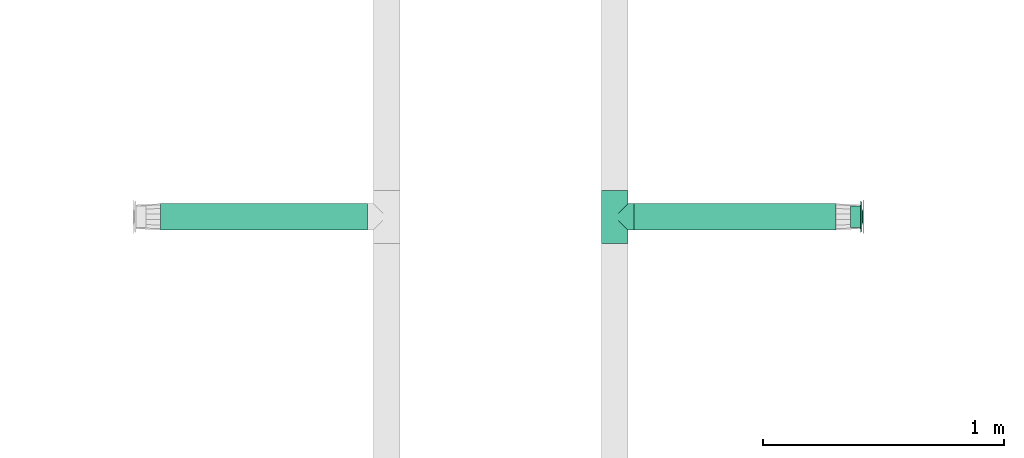
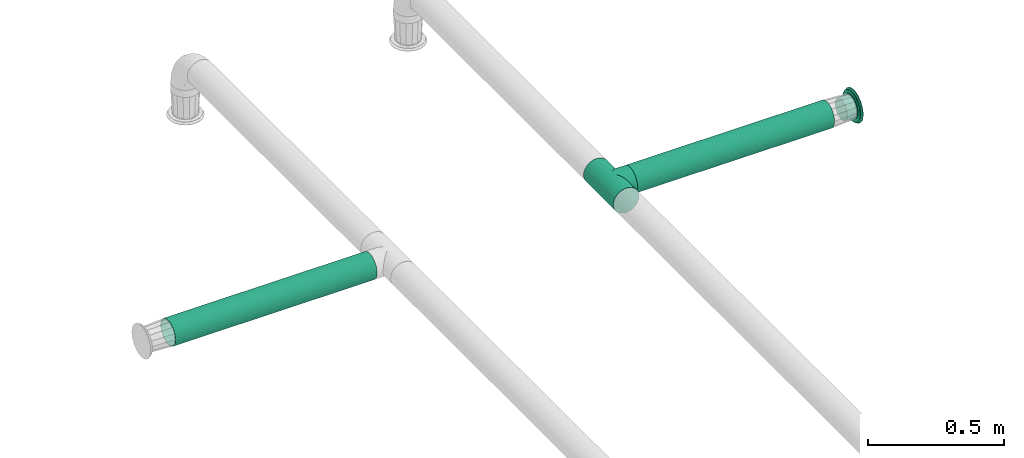
# One storey, part 40 of 123: 2 flow segments, 1 flow fitting, 1 flow terminal.
"""IFC2X3 building model written with IfcOpenShell, lengths in millimetres."""

from ifc_helpers import new_model, entity, si_unit, converted_unit, derived_unit, direction, frame, origin_with_axes, origin_2d_with_axis, place, context, subcontext, project, spatial, hollow_circle, extrude, open_shell, surface_model, source, transform, mapped, material, layer, layer_set, layer_usage, type_object, element, save


model = new_model("IFC2X3")

# Units and contexts
model_context = context("Model", 3, precision=1e-05, world=origin_with_axes(), true_north=direction((0.0, 1.0)))
body_context = subcontext(model_context, "Body", "Model", "MODEL_VIEW")
ifc_project = project(units=[si_unit("AREAUNIT", "SQUARE_METRE"), si_unit("VOLUMEUNIT", "CUBIC_METRE", prefix="DECI"), si_unit("TIMEUNIT", "SECOND"), si_unit("THERMODYNAMICTEMPERATUREUNIT", "DEGREE_CELSIUS"), si_unit("PRESSUREUNIT", "PASCAL"), si_unit("MASSUNIT", "GRAM", prefix="KILO"), si_unit("LENGTHUNIT", "METRE", prefix="MILLI"), si_unit("POWERUNIT", "WATT"), si_unit("ELECTRICCURRENTUNIT", "AMPERE"), si_unit("ELECTRICVOLTAGEUNIT", "VOLT"), derived_unit("VOLUMETRICFLOWRATEUNIT", [(si_unit("VOLUMEUNIT", "CUBIC_METRE", prefix="DECI"), 1), (si_unit("TIMEUNIT", "SECOND"), -1)]), derived_unit("LINEARVELOCITYUNIT", [(si_unit("LENGTHUNIT", "METRE"), 1), (si_unit("TIMEUNIT", "SECOND"), -1)]), derived_unit("MASSDENSITYUNIT", [(si_unit("MASSUNIT", "GRAM", prefix="KILO"), 1), (si_unit("VOLUMEUNIT", "CUBIC_METRE"), -1)]), converted_unit("PLANEANGLEUNIT", "DEGREE", entity("IfcRatioMeasure", 0.01745), si_unit("PLANEANGLEUNIT", "RADIAN"), dimensions=[0, 0, 0, 0, 0, 0, 0])], contexts=[model_context])

# Site, building, storey
site_placement = place(None, origin_with_axes())
site = spatial("IfcSite", under=ifc_project, at=site_placement, CompositionType="ELEMENT")
building_placement = place(site_placement, origin_with_axes())
building = spatial("IfcBuilding", under=site, at=building_placement, Name="mc-building", CompositionType="ELEMENT")
storey_placement = place(building_placement, origin_with_axes())
storey = spatial("IfcBuildingStorey", under=building, at=storey_placement, Name="1. Korrus", CompositionType="ELEMENT", Elevation=0.0)

# Flow terminal
air_terminal_type = type_object("IfcAirTerminalType", Name="100", PredefinedType="NOTDEFINED")
shared_shape_1 = source(origin_with_axes(), body_context, "Body", "SurfaceModel", [
    surface_model("IfcShellBasedSurfaceModel", [(11.2, 18.11733, -67.61481), (11.2, -18.11733, -67.61481), (11.2, 0.0, -70.0), (11.2, 67.61481, -18.11733), (11.2, 35.0, -60.62178), (11.2, 49.49747, -49.49747), (11.2, 60.62178, -35.0), (11.2, -67.61481, 18.11733), (11.2, -49.49747, -49.49747), (11.2, -67.61481, -18.11733), (11.2, -35.0, -60.62178), (11.2, -60.62178, -35.0), (11.2, -70.0, 0.0), (11.2, 18.11733, 67.61481), (11.2, 70.0, 0.0), (11.2, 67.61481, 18.11733), (11.2, 49.49747, 49.49747), (11.2, 60.62178, 35.0), (11.2, 35.0, 60.62178), (11.2, -49.49747, 49.49747), (11.2, -60.62178, 35.0), (11.2, -35.0, 60.62178), (11.2, -18.11733, 67.61481), (11.2, 0.0, 70.0), (9.2, 18.11733, 67.61481), (9.2, -67.61481, 18.11733), (9.2, 0.0, 70.0), (9.2, 49.49747, 49.49747), (9.2, 35.0, 60.62178), (9.2, 60.62178, 35.0), (9.2, 67.61481, 18.11733), (9.2, -35.0, 60.62178), (9.2, -49.49747, 49.49747), (9.2, -18.11733, 67.61481), (9.2, -60.62178, 35.0), (9.2, -67.61481, -18.11733), (9.2, -70.0, 0.0), (9.2, 67.61481, -18.11733), (9.2, 18.11733, -67.61481), (9.2, 49.49747, -49.49747), (9.2, 60.62178, -35.0), (9.2, 35.0, -60.62178), (9.2, -18.11733, -67.61481), (9.2, -49.49747, -49.49747), (9.2, -60.62178, -35.0), (9.2, -35.0, -60.62178), (9.2, 0.0, -70.0), (9.2, 70.0, 0.0), (9.2, 32.75, 0.0), (9.2, -16.375, 28.36233), (9.2, -28.36233, 16.375), (9.2, 16.375, 28.36233), (9.2, 0.0, 32.75), (9.2, 28.36233, 16.375), (9.2, -32.75, 0.0), (9.2, -16.375, -28.36233), (9.2, 16.375, -28.36233), (9.2, 0.0, -32.75), (9.2, 28.36233, -16.375), (9.2, -28.36233, -16.375), (6.2, -21.19625, -15.39997), (6.2, -21.19625, 15.39997), (6.2, 8.09625, 24.91768), (6.2, -8.09625, 24.91768), (6.2, -26.2, 0.0), (6.2, 21.19625, 15.39997), (6.2, -8.09625, -24.91768), (6.2, 21.19625, -15.39997), (6.2, 8.09625, -24.91768), (6.2, 26.2, 0.0), (9.2, 31.06579, -6.28555), (6.2, 23.69812, -7.69999), (6.2, -14.64625, -20.15883), (9.2, -22.36867, -22.36867), (6.2, -23.69812, -7.69999), (9.2, -31.06579, -6.28555), (6.2, 14.64625, -20.15883), (9.2, 8.1875, -30.55617), (6.2, 0.0, -24.91768), (9.2, 22.36867, -22.36867), (9.2, -8.1875, -30.55617), (9.2, -31.06579, 6.28555), (6.2, -23.69812, 7.69999), (6.2, 14.64625, 20.15883), (9.2, 22.36867, 22.36867), (6.2, 23.69812, 7.69999), (9.2, 31.06579, 6.28555), (6.2, -14.64625, 20.15883), (9.2, -8.1875, 30.55617), (6.2, 0.0, 24.91768), (9.2, -22.36867, 22.36867), (9.2, 8.1875, 30.55617), (6.2, -13.11761, 57.472), (6.2, -36.75472, 46.08897), (6.2, -53.11211, 25.57744), (6.2, 36.75472, 46.08897), (6.2, -58.95, 0.0), (6.2, 13.11761, 57.472), (6.2, 53.11211, 25.57744), (6.2, -53.11211, -25.57744), (6.2, -36.75472, -46.08897), (6.2, -13.11761, -57.472), (6.2, 58.95, 0.0), (6.2, 53.11211, -25.57744), (6.2, 13.11761, -57.472), (6.2, 36.75472, -46.08897), (0.0, -60.51411, 25.06576), (0.0, 0.0, 65.5), (0.0, 25.06576, 60.51411), (0.0, 46.3155, 46.3155), (0.0, 60.51411, 25.06576), (0.0, -46.3155, 46.3155), (0.0, -25.06576, 60.51411), (0.0, 0.0, -65.5), (0.0, -65.5, 0.0), (0.0, 65.5, 0.0), (0.0, 60.51411, -25.06576), (0.0, 46.3155, -46.3155), (0.0, 25.06576, -60.51411), (0.0, -46.3155, -46.3155), (0.0, -60.51411, -25.06576), (0.0, -25.06576, -60.51411), (6.2, 56.03105, -12.78872), (0.0, 53.4148, -35.69063), (0.0, 35.69063, -53.4148), (6.2, 24.93616, -51.78048), (0.0, -12.53288, -63.00706), (6.2, 0.0, -57.472), (0.0, -35.69063, -53.4148), (0.0, 63.00706, -12.53288), (6.2, 44.93342, -35.83321), (6.2, -24.93616, -51.78048), (6.2, -44.93342, -35.83321), (0.0, -53.4148, -35.69063), (0.0, 12.53288, -63.00706), (6.2, -56.03105, -12.78872), (0.0, -63.00706, -12.53288), (6.2, -56.03105, 12.78872), (0.0, -53.4148, 35.69063), (0.0, -35.69063, 53.4148), (6.2, -24.93616, 51.78048), (0.0, 12.53288, 63.00706), (6.2, 0.0, 57.472), (0.0, 35.69063, 53.4148), (0.0, -63.00706, 12.53288), (6.2, -44.93342, 35.83321), (6.2, 24.93616, 51.78048), (6.2, 44.93342, 35.83321), (0.0, 53.4148, 35.69063), (0.0, -12.53288, 63.00706), (6.2, 56.03105, 12.78872), (0.0, 63.00706, 12.53288), (-3.1, 12.94095, 48.29629), (-3.1, -35.35534, 35.35534), (-3.1, 0.0, 50.0), (-3.1, 35.35534, 35.35534), (-3.1, 25.0, 43.30127), (-3.1, -43.30127, 25.0), (-3.1, 43.30127, 25.0), (-3.1, -48.29629, -12.94095), (-3.1, -12.94095, 48.29629), (-3.1, -25.0, 43.30127), (-3.1, -50.0, 0.0), (-3.1, -48.29629, 12.94095), (-3.1, 48.29629, 12.94095), (-3.1, 12.94095, -48.29629), (-3.1, 50.0, 0.0), (-3.1, 48.29629, -12.94095), (-3.1, 35.35534, -35.35534), (-3.1, 43.30127, -25.0), (-3.1, 25.0, -43.30127), (-3.1, 0.0, -50.0), (-3.1, -35.35534, -35.35534), (-3.1, -43.30127, -25.0), (-3.1, -25.0, -43.30127), (-3.1, -12.94095, -48.29629), (0.0, 25.0, -43.30127), (0.0, 0.0, -50.0), (0.0, 12.94095, -48.29629), (0.0, 48.29629, -12.94095), (0.0, 35.35534, -35.35534), (0.0, -25.0, -43.30127), (0.0, 43.30127, -25.0), (0.0, -50.0, 0.0), (0.0, -12.94095, -48.29629), (0.0, -35.35534, -35.35534), (0.0, -48.29629, -12.94095), (0.0, -43.30127, -25.0), (0.0, 50.0, 0.0), (0.0, 43.30127, 25.0), (0.0, 12.94095, 48.29629), (0.0, 35.35534, 35.35534), (0.0, 25.0, 43.30127), (0.0, 0.0, 50.0), (0.0, -35.35534, 35.35534), (0.0, -43.30127, 25.0), (0.0, -48.29629, 12.94095), (0.0, -12.94095, 48.29629), (0.0, -25.0, 43.30127), (0.0, 48.29629, 12.94095), (-43.1, 0.0, 45.0), (-43.1, 11.64686, 43.46666), (-43.1, 22.5, 38.97115), (-43.1, -11.64686, 43.46666), (-43.1, 38.97115, 22.5), (-43.1, 43.46666, 11.64686), (-43.1, 31.81981, 31.81981), (-43.1, -22.5, 38.97115), (-43.1, -43.46666, 11.64686), (-43.1, -31.81981, 31.81981), (-43.1, -38.97115, 22.5), (-43.1, -45.0, 0.0), (-43.1, -43.46666, -11.64686), (-43.1, 45.0, 0.0), (-43.1, 43.46666, -11.64686), (-43.1, 38.97115, -22.5), (-43.1, 31.81981, -31.81981), (-43.1, 22.5, -38.97115), (-43.1, 11.64686, -43.46666), (-43.1, -31.81981, -31.81981), (-43.1, -38.97115, -22.5), (-43.1, -22.5, -38.97115), (-43.1, 0.0, -45.0), (-43.1, -11.64686, -43.46666), (-3.1, 22.5, -38.97115), (-3.1, 0.0, -45.0), (-3.1, 11.64686, -43.46666), (-3.1, 31.81981, -31.81981), (-3.1, -22.5, -38.97115), (-3.1, 38.97115, -22.5), (-3.1, 43.46666, -11.64686), (-3.1, 45.0, 0.0), (-3.1, -45.0, 0.0), (-3.1, -11.64686, -43.46666), (-3.1, -31.81981, -31.81981), (-3.1, -43.46666, -11.64686), (-3.1, -38.97115, -22.5), (-3.1, 0.0, 45.0), (-3.1, 43.46666, 11.64686), (-3.1, 38.97115, 22.5), (-3.1, 22.5, 38.97115), (-3.1, 31.81981, 31.81981), (-3.1, 11.64686, 43.46666), (-3.1, -11.64686, 43.46666), (-3.1, -43.46666, 11.64686), (-3.1, -31.81981, 31.81981), (-3.1, -38.97115, 22.5), (-3.1, -22.5, 38.97115)], [open_shell([[[0, 1, 2]], [[3, 0, 4]], [[5, 6, 3]], [[5, 3, 4]], [[7, 1, 0]], [[8, 7, 9]], [[10, 7, 8]], [[8, 9, 11]], [[12, 9, 7]], [[1, 7, 10]], [[7, 0, 3]], [[13, 14, 15]], [[16, 15, 17]], [[16, 18, 13]], [[16, 13, 15]], [[14, 13, 7]], [[7, 19, 20]], [[19, 7, 21]], [[7, 22, 21]], [[22, 7, 23]], [[7, 13, 23]], [[14, 7, 3]], [[24, 25, 26]], [[27, 24, 28]], [[27, 29, 30]], [[27, 30, 24]], [[25, 24, 30]], [[31, 25, 32]], [[25, 31, 33]], [[32, 25, 34]], [[33, 26, 25]], [[25, 35, 36]], [[25, 30, 37]], [[25, 37, 38]], [[39, 37, 40]], [[39, 41, 38]], [[39, 38, 37]], [[38, 42, 25]], [[35, 43, 44]], [[35, 25, 43]], [[45, 43, 25]], [[42, 45, 25]], [[38, 46, 42]], [[37, 30, 47]], [[35, 9, 36]], [[44, 11, 35]], [[10, 43, 45]], [[44, 43, 8]], [[1, 45, 42]], [[35, 11, 9]], [[9, 12, 36]], [[1, 10, 45]], [[8, 43, 10]], [[8, 11, 44]], [[2, 1, 42]], [[42, 46, 2]], [[38, 0, 46]], [[41, 4, 38]], [[6, 39, 40]], [[41, 39, 5]], [[3, 40, 37]], [[41, 5, 4]], [[4, 0, 38]], [[14, 3, 37]], [[6, 40, 3]], [[6, 5, 39]], [[47, 14, 37]], [[46, 0, 2]], [[30, 15, 47]], [[29, 17, 30]], [[18, 27, 28]], [[29, 27, 16]], [[13, 28, 24]], [[30, 17, 15]], [[15, 14, 47]], [[13, 18, 28]], [[16, 27, 18]], [[16, 17, 29]], [[23, 13, 24]], [[24, 26, 23]], [[33, 22, 26]], [[31, 21, 33]], [[20, 32, 34]], [[31, 32, 19]], [[7, 34, 25]], [[31, 19, 21]], [[21, 22, 33]], [[12, 7, 25]], [[20, 34, 7]], [[20, 19, 32]], [[36, 12, 25]], [[26, 22, 23]], [[48, 49, 50]], [[48, 51, 49]], [[49, 51, 52]], [[53, 51, 48]], [[48, 50, 54]], [[54, 55, 48]], [[56, 55, 57]], [[55, 58, 48]], [[58, 55, 56]], [[55, 54, 59]], [[60, 61, 62]], [[62, 61, 63]], [[64, 61, 60]], [[62, 65, 66]], [[67, 68, 65]], [[66, 60, 62]], [[65, 68, 66]], [[69, 67, 65]], [[69, 48, 70]], [[58, 71, 70]], [[72, 73, 60]], [[59, 74, 60]], [[75, 64, 74]], [[56, 68, 76]], [[72, 66, 55]], [[73, 72, 55]], [[68, 77, 78]], [[64, 75, 54]], [[59, 75, 74]], [[70, 71, 69]], [[67, 79, 76]], [[80, 55, 66]], [[68, 56, 77]], [[56, 76, 79]], [[79, 67, 58]], [[71, 58, 67]], [[80, 78, 57]], [[77, 57, 78]], [[66, 78, 80]], [[59, 60, 73]], [[64, 54, 81]], [[50, 82, 81]], [[83, 84, 65]], [[53, 85, 65]], [[86, 69, 85]], [[49, 63, 87]], [[83, 62, 51]], [[84, 83, 51]], [[63, 88, 89]], [[69, 86, 48]], [[53, 86, 85]], [[81, 82, 64]], [[61, 90, 87]], [[91, 51, 62]], [[63, 49, 88]], [[49, 87, 90]], [[90, 61, 50]], [[82, 50, 61]], [[91, 89, 52]], [[88, 52, 89]], [[62, 89, 91]], [[53, 65, 84]], [[92, 93, 94]], [[95, 94, 96]], [[97, 92, 95]], [[95, 92, 94]], [[96, 98, 95]], [[96, 99, 98]], [[99, 100, 101]], [[101, 102, 98]], [[102, 101, 103]], [[104, 105, 103]], [[101, 104, 103]], [[101, 98, 99]], [[106, 107, 108]], [[109, 110, 108]], [[106, 108, 110]], [[111, 112, 106]], [[106, 112, 107]], [[106, 113, 114]], [[106, 110, 113]], [[115, 116, 117]], [[117, 113, 110]], [[113, 117, 118]], [[114, 119, 120]], [[121, 119, 114]], [[121, 114, 113]], [[115, 117, 110]], [[103, 116, 122]], [[123, 116, 103]], [[124, 125, 118]], [[101, 126, 127]], [[100, 119, 128]], [[102, 122, 129]], [[103, 130, 123]], [[102, 129, 115]], [[113, 127, 126]], [[125, 124, 105]], [[130, 105, 117]], [[118, 125, 104]], [[124, 117, 105]], [[131, 100, 128]], [[119, 100, 132]], [[133, 99, 120]], [[134, 118, 104]], [[122, 116, 129]], [[127, 134, 104]], [[131, 121, 101]], [[99, 133, 132]], [[128, 121, 131]], [[130, 117, 123]], [[101, 121, 126]], [[99, 135, 120]], [[96, 136, 135]], [[136, 120, 135]], [[134, 127, 113]], [[133, 119, 132]], [[136, 96, 114]], [[94, 106, 137]], [[138, 106, 94]], [[139, 140, 112]], [[97, 141, 142]], [[95, 109, 143]], [[96, 137, 144]], [[94, 145, 138]], [[96, 144, 114]], [[107, 142, 141]], [[140, 139, 93]], [[145, 93, 111]], [[112, 140, 92]], [[139, 111, 93]], [[146, 95, 143]], [[109, 95, 147]], [[148, 98, 110]], [[149, 112, 92]], [[137, 106, 144]], [[142, 149, 92]], [[146, 108, 97]], [[98, 148, 147]], [[143, 108, 146]], [[145, 111, 138]], [[97, 108, 141]], [[98, 150, 110]], [[102, 151, 150]], [[151, 110, 150]], [[149, 142, 107]], [[148, 109, 147]], [[151, 102, 115]], [[152, 153, 154]], [[155, 152, 156]], [[157, 152, 158]], [[158, 152, 155]], [[158, 159, 157]], [[160, 153, 161]], [[160, 154, 153]], [[157, 162, 163]], [[153, 152, 157]], [[157, 159, 162]], [[158, 164, 159]], [[165, 166, 167]], [[168, 167, 169]], [[170, 165, 167]], [[170, 167, 168]], [[166, 165, 171]], [[159, 172, 173]], [[172, 159, 174]], [[174, 171, 175]], [[159, 164, 174]], [[166, 171, 174]], [[174, 164, 166]], [[176, 177, 178]], [[179, 176, 180]], [[176, 179, 181]], [[179, 180, 182]], [[179, 183, 181]], [[177, 181, 184]], [[177, 176, 181]], [[185, 186, 187]], [[186, 185, 181]], [[181, 183, 186]], [[183, 179, 188]], [[183, 188, 189]], [[190, 189, 191]], [[189, 190, 183]], [[190, 191, 192]], [[193, 194, 190]], [[183, 195, 196]], [[183, 190, 195]], [[194, 197, 198]], [[194, 195, 190]], [[197, 194, 193]], [[189, 188, 199]], [[164, 199, 166]], [[158, 189, 164]], [[192, 155, 156]], [[158, 155, 191]], [[190, 156, 152]], [[164, 189, 199]], [[199, 188, 166]], [[190, 192, 156]], [[191, 155, 192]], [[191, 189, 158]], [[193, 190, 152]], [[152, 154, 193]], [[160, 197, 154]], [[161, 198, 160]], [[195, 153, 157]], [[161, 153, 194]], [[196, 157, 163]], [[161, 194, 198]], [[198, 197, 160]], [[183, 196, 163]], [[195, 157, 196]], [[195, 194, 153]], [[162, 183, 163]], [[154, 197, 193]], [[159, 186, 162]], [[173, 187, 159]], [[181, 172, 174]], [[173, 172, 185]], [[184, 174, 175]], [[159, 187, 186]], [[186, 183, 162]], [[184, 181, 174]], [[185, 172, 181]], [[185, 187, 173]], [[177, 184, 175]], [[175, 171, 177]], [[165, 178, 171]], [[170, 176, 165]], [[182, 168, 169]], [[170, 168, 180]], [[179, 169, 167]], [[170, 180, 176]], [[176, 178, 165]], [[188, 179, 167]], [[182, 169, 179]], [[182, 180, 168]], [[166, 188, 167]], [[171, 178, 177]], [[200, 201, 202]], [[203, 200, 202]], [[204, 205, 202]], [[204, 202, 206]], [[203, 202, 205]], [[207, 208, 209]], [[207, 203, 205]], [[209, 208, 210]], [[211, 208, 212]], [[208, 207, 212]], [[207, 205, 212]], [[213, 214, 215]], [[205, 215, 212]], [[212, 216, 217]], [[216, 212, 215]], [[218, 219, 217]], [[212, 219, 220]], [[212, 217, 219]], [[221, 222, 223]], [[222, 221, 219]], [[218, 222, 219]], [[215, 205, 213]], [[224, 225, 226]], [[227, 228, 224]], [[229, 230, 231]], [[228, 227, 229]], [[229, 232, 228]], [[225, 228, 233]], [[225, 224, 228]], [[234, 235, 236]], [[235, 234, 228]], [[228, 232, 235]], [[232, 229, 231]], [[237, 238, 239]], [[240, 239, 241]], [[240, 242, 237]], [[240, 237, 239]], [[238, 237, 243]], [[244, 245, 246]], [[247, 244, 232]], [[244, 247, 245]], [[232, 238, 247]], [[238, 243, 247]], [[238, 232, 231]], [[205, 238, 213]], [[204, 239, 205]], [[240, 206, 202]], [[204, 206, 241]], [[242, 202, 201]], [[205, 239, 238]], [[238, 231, 213]], [[240, 202, 242]], [[241, 206, 240]], [[241, 239, 204]], [[201, 237, 242]], [[201, 200, 237]], [[243, 203, 207]], [[209, 247, 207]], [[246, 210, 208]], [[209, 210, 245]], [[244, 208, 211]], [[203, 243, 200]], [[207, 247, 243]], [[200, 243, 237]], [[209, 245, 247]], [[210, 246, 245]], [[244, 246, 208]], [[211, 232, 244]], [[212, 235, 211]], [[220, 236, 212]], [[228, 219, 221]], [[220, 219, 234]], [[233, 221, 223]], [[212, 236, 235]], [[235, 232, 211]], [[233, 228, 221]], [[234, 219, 228]], [[234, 236, 220]], [[225, 233, 223]], [[223, 222, 225]], [[226, 218, 217]], [[216, 224, 217]], [[229, 215, 214]], [[216, 215, 227]], [[230, 214, 213]], [[218, 226, 222]], [[217, 224, 226]], [[222, 226, 225]], [[216, 227, 224]], [[215, 229, 227]], [[230, 229, 214]], [[213, 231, 230]]])]),
])
flow_terminal_placement = place(storey_placement, frame((17487.97051, 3217.8145, 2445.0), z_axis=(0.0, 0.0, 1.0), x_axis=(1.0, 0.0, 0.0)))
element("IfcFlowTerminal", 1, at=flow_terminal_placement, inside=storey, type_object=air_terminal_type, Name="100", context=body_context, shape_type="MappedRepresentation", body=[
    mapped(shared_shape_1, transform((0.0, 0.0, 0.0), scale=1.0)),
])

# Flow fitting
duct_fitting_type = type_object("IfcDuctFittingType", PredefinedType="JUNCTION")
shared_shape_2 = source(origin_with_axes(), body_context, "Body", "SurfaceModel", [
    surface_model("IfcShellBasedSurfaceModel", [(0.0, -80.0, -55.0), (14.23505, -80.0, -53.12592), (-14.23505, -80.0, -53.12592), (-53.12592, -80.0, 14.23505), (-27.5, -80.0, -47.63139), (-47.63139, -80.0, -27.5), (-38.89087, -80.0, -38.89087), (55.0, -80.0, 0.0), (53.12592, -80.0, 14.23505), (38.89087, -80.0, -38.89087), (27.5, -80.0, -47.63139), (53.12592, -80.0, -14.23505), (47.63139, -80.0, -27.5), (-53.12592, -80.0, -14.23505), (-47.63139, -80.0, 27.5), (-38.89087, -80.0, 38.89087), (14.23505, -80.0, 53.12592), (-27.5, -80.0, 47.63139), (-14.23505, -80.0, 53.12592), (47.63139, -80.0, 27.5), (38.89087, -80.0, 38.89087), (27.5, -80.0, 47.63139), (0.0, -80.0, 55.0), (-55.0, -80.0, 0.0), (0.0, 0.0, 55.0), (-7.4066, -7.4066, 54.49901), (-14.74521, -14.74521, 52.98659), (-21.93978, -21.93978, 50.43457), (-28.89905, -28.89905, 46.79578), (-35.50357, -35.50357, 42.00591), (-41.58668, -41.58668, 35.99373), (-46.92319, -46.92319, 28.69171), (-51.19777, -51.19777, 20.0945), (-50.37866, -80.0, 20.86752), (-54.01174, -54.01174, 10.37938), (-55.0, -55.0, 0.0), (-54.06296, -80.0, 7.11752), (-54.01174, -54.01174, -10.37938), (-51.19777, -51.19777, -20.0945), (-54.06296, -80.0, -7.11752), (-46.92319, -46.92319, -28.69171), (-41.58668, -41.58668, -35.99373), (-50.37866, -80.0, -20.86752), (-35.50357, -35.50357, -42.00591), (-21.93978, -21.93978, -50.43457), (-14.74521, -14.74521, -52.98659), (-7.4066, -7.4066, -54.49901), (0.0, 0.0, -55.0), (-28.89905, -28.89905, -46.79578), (7.4066, -7.4066, -54.49901), (14.74521, -14.74521, -52.98659), (21.93978, -21.93978, -50.43457), (28.89905, -28.89905, -46.79578), (35.50357, -35.50357, -42.00591), (41.58668, -41.58668, -35.99373), (46.92319, -46.92319, -28.69171), (51.19777, -51.19777, -20.0945), (50.37866, -80.0, -20.86752), (54.01174, -54.01174, -10.37938), (55.0, -55.0, 0.0), (54.06296, -80.0, -7.11752), (54.01174, -54.01174, 10.37938), (51.19777, -51.19777, 20.0945), (54.06296, -80.0, 7.11752), (46.92319, -46.92319, 28.69171), (41.58668, -41.58668, 35.99373), (50.37866, -80.0, 20.86752), (35.50357, -35.50357, 42.00591), (21.93978, -21.93978, 50.43457), (14.74521, -14.74521, 52.98659), (7.4066, -7.4066, 54.49901), (28.89905, -28.89905, 46.79578), (-110.0, 0.0, -55.0), (-110.0, -14.23505, -53.12592), (-110.0, 14.23505, -53.12592), (-110.0, 53.12592, 14.23505), (-110.0, 27.5, -47.63139), (-110.0, 47.63139, -27.5), (-110.0, 38.89087, -38.89087), (-110.0, -55.0, 0.0), (-110.0, -53.12592, 14.23505), (-110.0, -38.89087, -38.89087), (-110.0, -27.5, -47.63139), (-110.0, -53.12592, -14.23505), (-110.0, -47.63139, -27.5), (-110.0, 53.12592, -14.23505), (-110.0, 47.63139, 27.5), (-110.0, 38.89087, 38.89087), (-110.0, -14.23505, 53.12592), (-110.0, 27.5, 47.63139), (-110.0, 14.23505, 53.12592), (-110.0, -47.63139, 27.5), (-110.0, -38.89087, 38.89087), (-110.0, -27.5, 47.63139), (-110.0, 0.0, 55.0), (-110.0, 55.0, 0.0), (110.0, 55.0, 0.0), (110.0, 0.0, -55.0), (110.0, 14.23505, -53.12592), (110.0, 27.5, -47.63139), (110.0, 38.89087, -38.89087), (110.0, 47.63139, -27.5), (110.0, -38.89087, -38.89087), (110.0, -53.12592, 14.23505), (110.0, -27.5, -47.63139), (110.0, -14.23505, -53.12592), (110.0, -47.63139, -27.5), (110.0, -53.12592, -14.23505), (110.0, -55.0, 0.0), (110.0, 53.12592, -14.23505), (110.0, 53.12592, 14.23505), (110.0, 47.63139, 27.5), (110.0, 38.89087, 38.89087), (110.0, 0.0, 55.0), (110.0, 27.5, 47.63139), (110.0, 14.23505, 53.12592), (110.0, -47.63139, 27.5), (110.0, -38.89087, 38.89087), (110.0, -27.5, 47.63139), (110.0, -14.23505, 53.12592)], [open_shell([[[0, 1, 2]], [[2, 3, 4]], [[5, 6, 3]], [[6, 4, 3]], [[2, 7, 8]], [[9, 7, 10]], [[1, 10, 7]], [[11, 7, 12]], [[9, 12, 7]], [[7, 2, 1]], [[5, 3, 13]], [[2, 14, 3]], [[2, 15, 14]], [[2, 16, 17]], [[17, 15, 2]], [[16, 18, 17]], [[2, 8, 19]], [[2, 19, 20]], [[2, 20, 21]], [[16, 2, 21]], [[16, 22, 18]], [[23, 13, 3]], [[24, 25, 22]], [[26, 27, 18]], [[25, 26, 18]], [[22, 25, 18]], [[17, 28, 29]], [[17, 18, 27]], [[17, 29, 15]], [[28, 17, 27]], [[30, 31, 14]], [[32, 3, 33]], [[32, 34, 3]], [[35, 36, 34]], [[31, 32, 14]], [[15, 30, 14]], [[34, 36, 3]], [[33, 14, 32]], [[36, 35, 23]], [[30, 15, 29]], [[37, 38, 13]], [[37, 13, 39]], [[40, 41, 5]], [[38, 5, 42]], [[38, 40, 5]], [[37, 39, 35]], [[35, 39, 23]], [[13, 38, 42]], [[41, 6, 5]], [[41, 43, 6]], [[44, 45, 2]], [[46, 47, 0]], [[45, 46, 2]], [[43, 48, 4]], [[44, 4, 48]], [[44, 2, 4]], [[46, 0, 2]], [[43, 4, 6]], [[47, 49, 0]], [[50, 51, 1]], [[49, 50, 1]], [[0, 49, 1]], [[10, 52, 53]], [[10, 1, 51]], [[10, 53, 9]], [[52, 10, 51]], [[54, 55, 12]], [[56, 11, 57]], [[56, 58, 11]], [[59, 60, 58]], [[55, 56, 12]], [[9, 54, 12]], [[58, 60, 11]], [[57, 12, 56]], [[60, 59, 7]], [[54, 9, 53]], [[61, 62, 8]], [[61, 8, 63]], [[64, 65, 19]], [[62, 19, 66]], [[62, 64, 19]], [[61, 63, 59]], [[7, 59, 63]], [[62, 66, 8]], [[65, 20, 19]], [[65, 67, 20]], [[68, 69, 16]], [[70, 24, 22]], [[69, 70, 16]], [[67, 71, 21]], [[68, 21, 71]], [[68, 16, 21]], [[70, 22, 16]], [[67, 21, 20]], [[72, 73, 74]], [[74, 75, 76]], [[77, 78, 75]], [[76, 75, 78]], [[74, 79, 80]], [[81, 79, 82]], [[73, 82, 79]], [[83, 79, 84]], [[81, 84, 79]], [[79, 74, 73]], [[77, 75, 85]], [[74, 86, 75]], [[74, 87, 86]], [[74, 88, 89]], [[89, 87, 74]], [[88, 90, 89]], [[74, 91, 92]], [[91, 74, 80]], [[92, 93, 74]], [[74, 93, 88]], [[88, 94, 90]], [[95, 85, 75]], [[96, 97, 98]], [[99, 96, 98]], [[96, 100, 101]], [[100, 96, 99]], [[102, 97, 103]], [[97, 102, 104]], [[104, 105, 97]], [[102, 103, 106]], [[106, 103, 107]], [[108, 107, 103]], [[109, 96, 101]], [[110, 111, 97]], [[97, 111, 112]], [[113, 97, 114]], [[97, 112, 114]], [[113, 114, 115]], [[116, 103, 97]], [[117, 116, 97]], [[118, 117, 97]], [[119, 118, 97]], [[119, 97, 113]], [[96, 110, 97]], [[24, 113, 115]], [[89, 115, 114]], [[94, 24, 90]], [[90, 24, 115]], [[115, 89, 90]], [[114, 87, 89]], [[86, 112, 111]], [[75, 111, 110]], [[95, 110, 96]], [[87, 112, 86]], [[86, 111, 75]], [[110, 95, 75]], [[112, 87, 114]], [[85, 96, 109]], [[77, 109, 101]], [[95, 96, 85]], [[85, 109, 77]], [[101, 78, 77]], [[101, 100, 78]], [[76, 100, 99]], [[74, 99, 98]], [[47, 98, 97]], [[76, 99, 74]], [[47, 72, 74]], [[98, 47, 74]], [[100, 76, 78]], [[47, 46, 72]], [[45, 44, 73]], [[46, 45, 73]], [[72, 46, 73]], [[82, 48, 43]], [[82, 73, 44]], [[82, 43, 81]], [[48, 82, 44]], [[41, 40, 84]], [[38, 37, 83]], [[40, 38, 84]], [[81, 41, 84]], [[37, 79, 83]], [[83, 84, 38]], [[79, 37, 35]], [[41, 81, 43]], [[49, 97, 105]], [[105, 104, 51]], [[53, 104, 102]], [[53, 52, 104]], [[49, 47, 97]], [[51, 50, 105]], [[52, 51, 104]], [[49, 105, 50]], [[54, 102, 106]], [[56, 106, 107]], [[58, 107, 108]], [[55, 54, 106]], [[58, 56, 107]], [[59, 58, 108]], [[55, 106, 56]], [[102, 54, 53]], [[34, 32, 80]], [[31, 30, 91]], [[32, 31, 91]], [[35, 34, 79]], [[80, 79, 34]], [[32, 91, 80]], [[30, 92, 91]], [[30, 29, 92]], [[27, 26, 88]], [[25, 24, 94]], [[26, 25, 88]], [[29, 28, 93]], [[27, 93, 28]], [[27, 88, 93]], [[25, 94, 88]], [[29, 93, 92]], [[61, 108, 103]], [[62, 103, 116]], [[65, 116, 117]], [[61, 59, 108]], [[64, 62, 116]], [[65, 64, 116]], [[61, 103, 62]], [[117, 67, 65]], [[71, 67, 118]], [[118, 67, 117]], [[68, 118, 119]], [[70, 119, 113]], [[68, 71, 118]], [[70, 69, 119]], [[24, 70, 113]], [[68, 119, 69]]])]),
])
flow_fitting_placement = place(storey_placement, frame((16466.11947, 3217.8145, 2445.0), z_axis=(0.0, 0.0, 1.0), x_axis=(0.0, 1.0, 0.0)))
element("IfcFlowFitting", 2, at=flow_fitting_placement, inside=storey, type_object=duct_fitting_type, context=body_context, shape_type="MappedRepresentation", body=[
    mapped(shared_shape_2, transform((0.0, 0.0, 0.0), scale=1.0)),
])

# Flow segments
ifc_material = material(Name="FZ1")
ifc_layer = layer(ifc_material, 0.0)
ifc_layer_set = layer_set([ifc_layer], Name="FZ1")
ifc_layer_usage = layer_usage(ifc_layer_set, "AXIS1", "POSITIVE", 0.0)
duct_segment_type = type_object("IfcDuctSegmentType", PredefinedType="RIGIDSEGMENT")
shared_shape_3 = source(origin_with_axes(), body_context, "Body", "SweptSolid", [
    extrude(hollow_circle(Radius=55.0, WallThickness=2.0, at=origin_2d_with_axis()), frame((0.0, 0.0, 0.0), z_axis=(1.0, 0.0, 0.0), x_axis=(0.0, 1.0, 0.0)), (0.0, 0.0, 1.0), 838.8),
])
flow_segment_1_placement = place(storey_placement, frame((16546.11947, 3217.8145, 2445.0), z_axis=(0.0, 0.0, 1.0), x_axis=(1.0, 0.0, 0.0)))
element("IfcFlowSegment", 3, at=flow_segment_1_placement, inside=storey, type_object=duct_segment_type, material=ifc_layer_usage, context=body_context, shape_type="MappedRepresentation", body=[
    mapped(shared_shape_3, transform((0.0, 0.0, 0.0), scale=1.0)),
])
shared_shape_4 = source(origin_with_axes(), body_context, "Body", "SweptSolid", [
    extrude(hollow_circle(Radius=55.0, WallThickness=2.0, at=origin_2d_with_axis()), frame((0.0, 0.0, 0.0), z_axis=(1.0, 0.0, 0.0), x_axis=(0.0, 1.0, 0.0)), (0.0, 0.0, 1.0), 858.8),
])
flow_segment_2_placement = place(storey_placement, frame((15437.82156, 3217.8145, 2445.0), z_axis=(0.0, 0.0, 1.0), x_axis=(-1.0, 0.0, 0.0)))
element("IfcFlowSegment", 4, at=flow_segment_2_placement, inside=storey, type_object=duct_segment_type, material=ifc_layer_usage, context=body_context, shape_type="MappedRepresentation", body=[
    mapped(shared_shape_4, transform((0.0, 0.0, 0.0), scale=1.0)),
])

save(model, "model.ifc")
